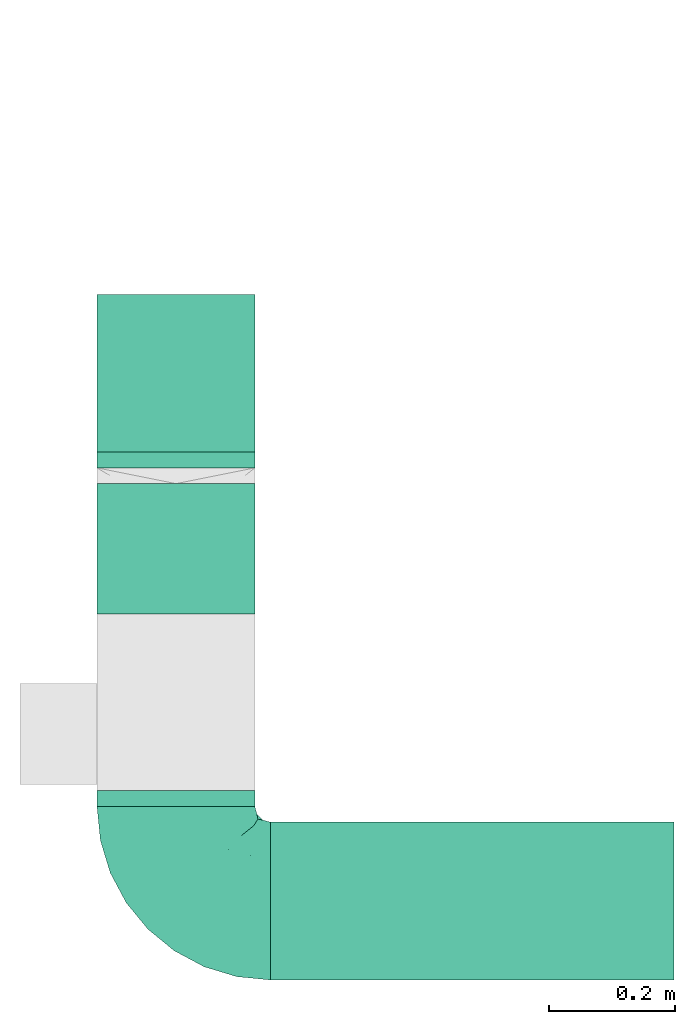
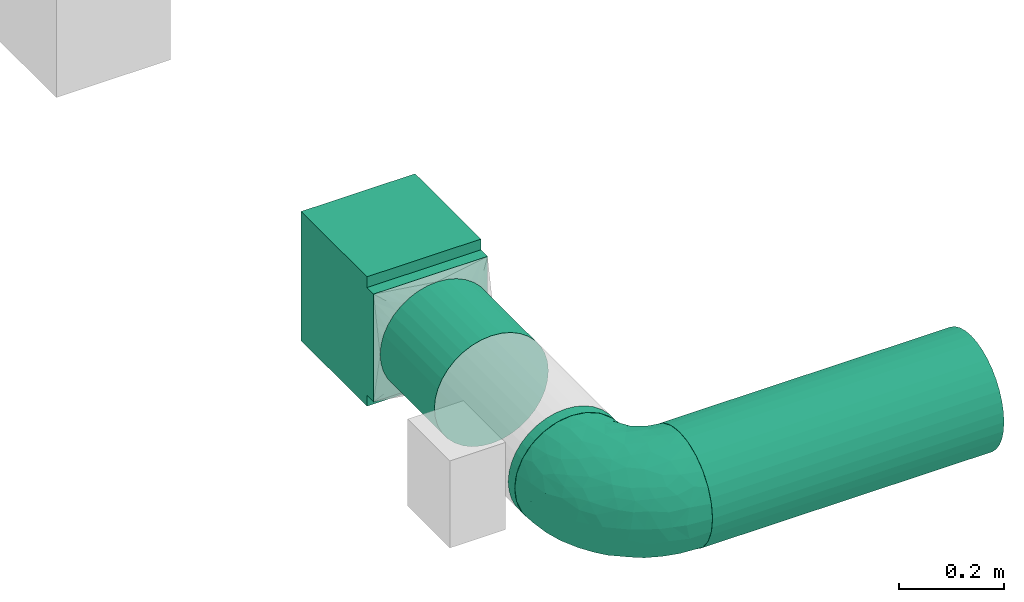
# One storey, part 1 of 4: 3 flow segments, 2 flow fittings.
"""IFC2X3 building model written with IfcOpenShell, lengths in millimetres."""

from ifc_helpers import new_model, entity, si_unit, converted_unit, derived_unit, direction, frame, origin, origin_2d_with_axis, place, context, subcontext, project, spatial, polyline, circle, outline, extrude, faceted_brep, source, transform, mapped, type_object, type_shapes, element, save


model = new_model("IFC2X3")

# Units and contexts
model_context = context("Model", 3, precision=0.01, world=origin(), true_north=direction((6.12303176911189e-17, 1.0)))
body_context = subcontext(model_context, "Body", "Model", "MODEL_VIEW")
ifc_project = project(units=[si_unit("LENGTHUNIT", "METRE", prefix="MILLI"), si_unit("AREAUNIT", "SQUARE_METRE"), si_unit("VOLUMEUNIT", "CUBIC_METRE"), converted_unit("PLANEANGLEUNIT", "DEGREE", entity("IfcRatioMeasure", 0.0174532925199433), si_unit("PLANEANGLEUNIT", "RADIAN"), dimensions=[0, 0, 0, 0, 0, 0, 0]), si_unit("MASSUNIT", "GRAM", prefix="KILO"), derived_unit("MASSDENSITYUNIT", [(si_unit("MASSUNIT", "GRAM", prefix="KILO"), 1), (si_unit("LENGTHUNIT", "METRE"), -3)]), si_unit("TIMEUNIT", "SECOND"), si_unit("FREQUENCYUNIT", "HERTZ"), si_unit("THERMODYNAMICTEMPERATUREUNIT", "DEGREE_CELSIUS"), derived_unit("THERMALTRANSMITTANCEUNIT", [(si_unit("MASSUNIT", "GRAM", prefix="KILO"), 1), (si_unit("THERMODYNAMICTEMPERATUREUNIT", "KELVIN"), -1), (si_unit("TIMEUNIT", "SECOND"), -3)]), derived_unit("VOLUMETRICFLOWRATEUNIT", [(si_unit("LENGTHUNIT", "METRE"), 3), (si_unit("TIMEUNIT", "SECOND"), -1)]), si_unit("ELECTRICCURRENTUNIT", "AMPERE"), si_unit("ELECTRICVOLTAGEUNIT", "VOLT"), si_unit("POWERUNIT", "WATT"), si_unit("FORCEUNIT", "NEWTON", prefix="KILO"), si_unit("ILLUMINANCEUNIT", "LUX"), si_unit("LUMINOUSFLUXUNIT", "LUMEN"), si_unit("LUMINOUSINTENSITYUNIT", "CANDELA"), derived_unit("USERDEFINED", [(si_unit("MASSUNIT", "GRAM", prefix="KILO"), -1), (si_unit("LENGTHUNIT", "METRE"), -2), (si_unit("TIMEUNIT", "SECOND"), 3), (si_unit("LUMINOUSFLUXUNIT", "LUMEN"), 1)]), derived_unit("LINEARVELOCITYUNIT", [(si_unit("LENGTHUNIT", "METRE"), 1), (si_unit("TIMEUNIT", "SECOND"), -1)]), si_unit("PRESSUREUNIT", "PASCAL"), derived_unit("USERDEFINED", [(si_unit("LENGTHUNIT", "METRE"), -2), (si_unit("MASSUNIT", "GRAM", prefix="KILO"), 1), (si_unit("TIMEUNIT", "SECOND"), -2)])], contexts=[model_context])

# Site, building, storey
site_placement = place(None, origin())
site = spatial("IfcSite", under=ifc_project, at=site_placement, CompositionType="ELEMENT")
building_placement = place(site_placement, origin())
building = spatial("IfcBuilding", under=site, at=building_placement, CompositionType="ELEMENT")
storey_placement = place(building_placement, frame((0.0, 0.0, 8000.0)))
storey = spatial("IfcBuildingStorey", under=building, at=storey_placement, Name="02 Level", CompositionType="ELEMENT", Elevation=8000.0)

# Flow segments
duct_segment_type = type_object("IfcDuctSegmentType", Name="Round Duct:Air", PredefinedType="NOTDEFINED")
flow_segment_1_placement = place(storey_placement, frame((25345.9632723171, -70384.05691443, 3383.40472776408)))
element("IfcFlowSegment", 1, at=flow_segment_1_placement, inside=storey, type_object=duct_segment_type, Name="Round Duct:Air", ObjectType="Round Duct:Air", context=body_context, shape_type="SweptSolid", body=[
    extrude(circle(Radius=125.0, at=origin_2d_with_axis()), frame((0.0, 126.595272235913, 126.595272235916), z_axis=(1.0, 0.0, 0.0), x_axis=(0.0, 1.0, 0.0)), (0.0, 0.0, 1.0), 639.200332511935),
])
flow_segment_2_placement = place(storey_placement, frame((25069.3680000811, -70107.4616421941, 3383.40472776408)))
element("IfcFlowSegment", 2, at=flow_segment_2_placement, inside=storey, type_object=duct_segment_type, Name="Round Duct:Air", ObjectType="Round Duct:Air", context=body_context, shape_type="SweptSolid", body=[
    extrude(circle(Radius=125.0, at=origin_2d_with_axis()), frame((126.595272235918, 0.0, 126.595272235916), z_axis=(0.0, 1.0, 0.0), x_axis=(1.0, 0.0, 0.0)), (0.0, 0.0, 1.0), 25.0000000001243),
])
flow_segment_3_placement = place(storey_placement, frame((25069.3680000811, -69802.4616421939, 3383.40472776408)))
element("IfcFlowSegment", 3, at=flow_segment_3_placement, inside=storey, type_object=duct_segment_type, Name="Round Duct:Air", ObjectType="Round Duct:Air", context=body_context, shape_type="SweptSolid", body=[
    extrude(circle(Radius=125.0, at=origin_2d_with_axis()), frame((126.595272235918, 0.0, 126.595272235916), z_axis=(0.0, 1.0, 0.0), x_axis=(1.0, 0.0, 0.0)), (0.0, 0.0, 1.0), 206.222057054006),
])

# Flow fittings
duct_fitting_type_1 = type_object("IfcDuctFittingType", Name="Air_Elbow short_Circ", PredefinedType="NOTDEFINED")
shared_shape_1 = source(origin(), body_context, "Body", "Brep", [
    faceted_brep([(-150.0, 0.0, -125.0), (-150.0, -32.3523806378149, -120.740728286134), (-150.0, -62.4999999999998, -108.253175473055), (-150.0, -88.3883476483182, -88.3883476483186), (-150.0, -108.253175473055, -62.5000000000003), (-150.0, -120.740728286133, -32.3523806378155), (-150.0, -123.435651957388, -11.8824030784058), (-150.0, -125.0, 0.0), (-150.0, -123.435651932551, 11.8824032670586), (-150.0, -120.740728286134, 32.3523806378147), (-150.0, -108.253175473055, 62.4999999999996), (-150.0, -88.3883476483188, 88.3883476483181), (-150.0, -62.5000000000004, 108.253175473055), (-150.0, -32.3523806378156, 120.740728286133), (-150.0, 0.0, 125.0), (-150.0, 32.3523806378145, 120.740728286134), (-150.0, 47.426190318907, 114.496951879594), (-150.0, 62.4999999999994, 108.253175473055), (-150.0, 88.3883476483179, 88.3883476483189), (-150.0, 108.253175473054, 62.5000000000006), (-150.0, 120.740728286133, 32.3523806378158), (-150.0, 125.0, 0.0), (-150.0, 120.740728286134, -32.3523806378151), (-150.0, 108.253175473055, -62.4999999999999), (-150.0, 88.3883476483185, -88.3883476483184), (-150.0, 62.5000000000001, -108.253175473055), (-150.0, 32.3523806378152, -120.740728286134), (-32.3523806378144, 150.0, -120.740728286134), (-47.4261903189069, 150.0, -114.496951879594), (-62.4999999999993, 150.0, -108.253175473055), (-88.3883476483177, 150.0, -88.3883476483184), (-108.253175473054, 150.0, -62.4999999999999), (-120.740728286133, 150.0, -32.3523806378151), (-125.0, 150.0, 0.0), (-120.740728286133, 150.0, 32.3523806378158), (-108.253175473054, 150.0, 62.5000000000006), (-88.3883476483171, 150.0, 88.3883476483189), (-62.4999999999986, 150.0, 108.253175473055), (-32.3523806378137, 150.0, 120.740728286134), (0.0, 150.0, 125.0), (32.3523806378164, 150.0, 120.740728286133), (62.5000000000013, 150.0, 108.253175473055), (88.3883476483196, 150.0, 88.3883476483181), (108.253175473056, 150.0, 62.4999999999996), (120.740728286134, 150.0, 32.3523806378147), (123.435651942407, 150.0, 11.8824031922038), (125.0, 150.0, 0.0), (123.435651967915, 150.0, -11.8824029984461), (120.740728286134, 150.0, -32.3523806378155), (108.253175473056, 150.0, -62.5000000000003), (88.3883476483191, 150.0, -88.3883476483186), (62.5000000000006, 150.0, -108.253175473055), (32.3523806378157, 150.0, -120.740728286134), (0.0, 150.0, -125.0), (78.654143383201, -2.78181408039032, 0.0), (76.8166118284912, 4.34215934351885, 36.4784551593461), (61.5542541047513, -23.6180894533453, 0.0), (-134.47520521655, -123.470941174946, 0.0), (-118.950410719399, -121.94188237809, 0.0), (-107.650286082481, -120.828917244489, 0.0), (-104.978291071801, -115.896211779269, 36.0762953828009), (-104.893239881748, -80.8641300661028, 91.4382355521353), (-72.3157335278814, -68.3433914970576, 94.5606631552989), (-98.4001040789566, -53.9628430343128, 109.445004780609), (-96.3501614455635, -119.715952110888, 0.0), (-42.4833938815038, 107.782088248638, 120.147094064889), (-9.85362544116063, 110.378344389653, 124.923923156167), (-65.0280946569744, -106.747383493999, 33.443557785531), (-86.153263795542, -100.695403874887, 61.7233478403087), (-46.6576932994355, -45.2628664218306, 102.931281147801), (-74.6225764033372, -21.2831891292868, 119.356425571857), (-72.3472176796021, 118.598046915095, 106.00707228478), (-30.181321363474, -90.8187429032163, 38.3247326160971), (-70.5561087725814, -111.891411775746, 0.0), (-122.641019976636, -101.950353756475, 70.1921456806148), (-116.029933078324, -22.4446697961388, 122.317161759311), (31.0815829535711, -16.1832151821723, 80.3202993154639), (-6.5545406401204, -44.0646866272317, 85.350831949551), (-3.87227453406602, -60.0293001979925, 66.4690229889152), (-124.863076426312, 35.02364091556, 120.752635411014), (-108.839291442555, 9.81519021738238, 124.939227930759), (-65.2460766604593, 23.6299006304857, 124.981338254694), (-100.878102436648, 43.0002899009219, 120.764526140437), (-19.3649461243935, 39.6901954019144, 123.22697540265), (-40.0496486471489, 1.9751024241996, 120.175633139922), (115.896212240375, 104.978289788922, 36.076293164084), (106.747383973922, 65.0280912143933, 33.4435522492635), (111.891411775747, 70.5561087725829, 0.0), (-128.779008055589, 97.2792215313154, 83.3343675755997), (-129.846276411156, 129.84627642804, 29.3795101662085), (-137.499999999999, 128.349364905389, 0.0), (-119.508978979081, 123.341462022577, 60.2918029167743), (-117.382833556128, 72.4228430829308, 106.251870907854), (-25.6262961621547, 80.1753214783878, 124.782747564482), (-131.548236956176, 110.790620858511, 65.1719471748524), (-8.79719392560859, -75.269004466267, 46.9066376982592), (-35.2869113408269, -83.3156317546561, 59.3885364241187), (80.8641305584726, 104.893240937849, 91.4382352904789), (22.4446672811422, 116.029929681511, 122.317162140699), (53.9628368321699, 98.4001001508859, 109.445007566679), (101.950355286479, 122.641017340516, 70.1921430199164), (-81.9960770469301, 82.9111806812523, 112.506499839482), (121.941882232658, 118.950409242795, 0.0), (71.251669566406, 11.4744102833441, 57.4040159418747), (72.0838963385765, 41.0064832243528, 78.3617835611187), (54.4859475333804, 9.97269301512521, 77.8031341973232), (23.6180894533467, -61.55425410475, 0.0), (32.5558794954592, -52.5906940820025, 23.8275763366719), (5.67366256371018, -73.4168733312184, 25.8218410570659), (-104.061743134415, 104.061741649423, 91.6204401768965), (100.695405783636, 86.1532561367086, 61.7233412541476), (85.8987630246562, 72.298942037013, 77.1305759551526), (45.2628557573736, 46.657677121917, 102.931282428265), (21.2831826839793, 74.6225676704571, 119.356426312895), (-128.349364905388, 137.5, 0.0), (-97.2792212827368, 128.779007172919, 83.3343682018964), (44.4543648263017, -44.4543648263003, 0.0), (-52.705139116163, 62.5335134626551, 123.521409265362), (-44.7620560995991, -104.066871440604, 0.0), (68.3433809087284, 72.3157185192085, 94.5606674302311), (39.0643086961098, -39.0643160658399, 42.9833221935425), (16.162962522349, -57.6081885852494, 46.7813378836038), (87.2978457655956, 45.1469719017519, 60.4141052051649), (-73.6770751262291, 45.4290804428845, 123.301126563982), (91.3605074119029, 20.9901210096052, 0.0), (104.066871440605, 44.7620560996006, 0.0), (90.8187420929716, 30.1813146205812, 38.3247255432369), (24.8419677176115, 18.7098050381526, 104.4628615233), (46.9444181295578, -18.5239913801244, 60.8208891980822), (13.0080717069866, -10.2820614252128, 97.1887902869043), (-29.5778446799892, -20.3201363536925, 110.417514778129), (-1.53394209146154, 80.1817000123714, 124.206375369784), (-65.4894356396677, -87.5368940232825, 72.0830916827234), (-3.04954297208558, 3.04952905280945, 110.823842282024), (9.92439824324807, 37.6446897703782, 116.445568419899), (2.7818140803917, -78.6541433831998, 0.0), (59.4075113977493, -18.3919768641063, 39.1397493302004), (-41.0065082221364, -72.0839038715865, 78.3617888442077), (-20.9901210096037, -91.3605074119017, 0.0), (119.715952110889, 96.3501614455651, 0.0), (-39.6901857853554, 19.3649451890522, -123.226974224734), (-62.5335140350356, 52.7051321522757, -123.521410009679), (-23.6299179988057, 65.2460778291534, -124.981338515222), (52.5906917601974, -32.5558816629036, -23.8275777472421), (73.4168733742841, -5.67366166885961, -25.8218433127719), (-110.378347073661, 9.85362190254904, -124.923923249535), (-35.0236472156293, 124.863059021426, -120.752634758897), (-107.782088925523, 42.4833910778036, -120.147094743061), (-104.978289397083, -115.896211531471, -36.0762952658108), (-86.1532622275364, -100.695403598284, -61.7233476308542), (-65.0280943433708, -106.747382926782, -33.4435593699909), (-129.846276430226, 129.846276387071, -29.3795102302433), (-110.790620399346, 131.548235360156, -65.1719489671012), (-123.341462756194, 119.508979301124, -60.291801599493), (-104.061744765902, 104.061740157582, -91.6204400852508), (-128.779008894392, 97.2792211868359, -83.3343675827014), (53.9628420250463, 98.4000971565888, -109.445004383699), (-118.598049105409, 72.3472165670435, -106.007072416171), (-82.9111719502085, 81.9960693312282, -112.50650546776), (-122.641019448242, -101.950353750649, -70.1921456050946), (-104.893238223024, -80.8641303146933, -91.4382350282511), (-98.4001019855057, -53.9628440035923, -109.445003978822), (80.8641292666627, 104.893234920637, -91.4382353967358), (-11.4744255033641, -71.2516789045734, -57.4040162551542), (-41.0065049684125, -72.0839032542554, -78.3617877513776), (-9.97270838371827, -54.485960500352, -77.8031316627462), (-4.34216444876671, -76.8166149897799, -36.4784554826068), (-80.1753222808587, 25.6262887954871, -124.782747920507), (-116.029931420384, -22.4446712385047, -122.317161393809), (68.3433887340013, 72.3157292909759, -94.5606641780198), (45.2628607882706, 46.6576825738772, -102.931281121668), (22.4446699556419, 116.029925989706, -122.317161437833), (-9.8151830458522, 108.839262459516, -124.939228400111), (-72.298953284581, -85.8987604849819, -77.1305835190378), (-97.2792209116865, 128.779005996318, -83.3343690779209), (-46.6576894105135, -45.2628676819038, -102.931279126956), (-72.3157308447408, -68.3433918222031, -94.5606621128927), (-72.422840670004, 117.382841409987, -106.251870399877), (21.2831853090833, 74.6225640045938, -119.356425105916), (101.950353353368, 122.641019823701, -70.1921462468134), (-43.0003002529277, 100.878091329174, -120.764524865091), (16.1832033989244, -31.0815970254922, -80.3202964529749), (44.0646797153192, 6.55452919959333, -85.3508306205825), (60.0292953493994, 3.87226817055985, -66.4690235395615), (115.896211010696, 104.978286786289, -36.0762955232767), (106.747381524869, 65.0280939101863, -33.4435636729749), (100.695402688448, 86.1532621979624, -61.7233491707037), (-1.97512261791953, 40.0496336831204, -120.175635225652), (83.315631357607, 35.2869127496766, -59.388538235289), (90.8187416032175, 30.181318578684, -38.3247323782698), (75.2690016288807, 8.79719117487841, -46.9066400280846), (18.5239820708271, -46.9444270147629, -60.8208879439308), (57.6081840561054, -16.162966744892, -46.7813401074288), (39.0643108807276, -39.0643133486842, -42.9833232218422), (-74.6225723501512, -21.2831916140966, -119.356424356291), (-45.1469861494655, -87.2978481709874, -60.4141116504016), (-45.4290965712264, 73.6770713110896, -123.301124768617), (-30.1813201883898, -90.818742779246, -38.3247313356157), (-18.7098212867178, -24.8419796072181, -104.462861687025), (10.2820459472016, -13.0080933749158, -97.1887865677227), (20.3201251027192, 29.5778424846975, -110.417518980415), (-80.1817048843535, 1.5339337664806, -124.206374751548), (87.5368918123803, 65.4894359750046, -72.0830947930252), (-3.04953343548765, 3.04952712079592, -110.823838051094), (-37.6446965781717, -9.92440491577136, -116.445567816425), (18.3919716152399, -59.4075155656008, -39.1397494553499), (72.083900742128, 41.0065066004899, -78.361791447751)], [[[0, 1, 2, 3, 4, 5, 6, 7, 8, 9, 10, 11, 12, 13, 14, 15, 16, 17, 18, 19, 20, 21, 22, 23, 24, 25, 26]], [[27, 28, 29, 30, 31, 32, 33, 34, 35, 36, 37, 38, 39, 40, 41, 42, 43, 44, 45, 46, 47, 48, 49, 50, 51, 52, 53]], [[54, 55, 56]], [[9, 8, 7, 57, 58, 59]], [[60, 10, 9]], [[61, 62, 63]], [[60, 59, 64]], [[38, 65, 66]], [[60, 67, 68]], [[12, 11, 61]], [[63, 12, 61]], [[63, 69, 70]], [[37, 36, 71]], [[72, 68, 67]], [[60, 73, 67]], [[11, 10, 74]], [[37, 71, 65]], [[13, 75, 14]], [[76, 77, 78]], [[17, 16, 15, 79]], [[80, 81, 82]], [[83, 81, 84]], [[85, 86, 87]], [[18, 88, 19]], [[89, 21, 20]], [[21, 89, 90]], [[89, 91, 34]], [[63, 62, 69]], [[17, 92, 18]], [[93, 66, 65]], [[19, 88, 94]], [[63, 70, 75]], [[95, 96, 72]], [[74, 60, 68]], [[41, 97, 42]], [[13, 12, 63]], [[40, 98, 99]], [[43, 42, 100]], [[65, 71, 101]], [[41, 40, 99]], [[85, 102, 44]], [[103, 104, 105]], [[41, 99, 97]], [[85, 44, 43]], [[106, 107, 108]], [[79, 92, 17]], [[102, 46, 45, 44]], [[71, 109, 101]], [[85, 110, 86]], [[97, 111, 110]], [[33, 89, 34]], [[112, 99, 113]], [[114, 89, 33]], [[94, 20, 19]], [[115, 91, 109]], [[116, 107, 106]], [[117, 81, 83]], [[91, 35, 34]], [[36, 35, 115]], [[118, 72, 67]], [[15, 14, 80]], [[112, 104, 119]], [[65, 38, 37]], [[66, 39, 38]], [[107, 120, 121]], [[122, 86, 110]], [[39, 98, 40]], [[75, 80, 14]], [[100, 85, 43]], [[123, 81, 117]], [[82, 123, 101]], [[88, 92, 109]], [[124, 125, 126]], [[127, 105, 112]], [[121, 128, 76]], [[77, 129, 130]], [[115, 71, 36]], [[109, 92, 101]], [[93, 65, 117]], [[66, 131, 98]], [[119, 97, 99]], [[100, 97, 110]], [[74, 61, 11]], [[132, 68, 96]], [[80, 70, 81]], [[84, 81, 70]], [[133, 134, 83]], [[93, 131, 66]], [[135, 106, 108]], [[72, 108, 95]], [[110, 111, 122]], [[136, 116, 56]], [[134, 112, 113]], [[112, 134, 127]], [[77, 69, 137]], [[84, 130, 133]], [[96, 78, 137]], [[129, 76, 127]], [[82, 101, 92]], [[65, 101, 117]], [[66, 98, 39]], [[99, 98, 113]], [[63, 75, 13]], [[80, 75, 70]], [[91, 115, 35]], [[71, 115, 109]], [[92, 88, 18]], [[94, 109, 91]], [[86, 125, 87]], [[135, 108, 138]], [[125, 86, 126]], [[87, 139, 85]], [[117, 83, 93]], [[83, 134, 131]], [[83, 131, 93]], [[98, 131, 113]], [[109, 94, 88]], [[94, 91, 89]], [[9, 59, 60]], [[102, 85, 139]], [[90, 89, 114]], [[89, 20, 94]], [[60, 74, 10]], [[61, 74, 68]], [[97, 100, 42]], [[85, 100, 110]], [[82, 92, 79]], [[15, 80, 79]], [[80, 82, 79]], [[121, 108, 107]], [[136, 107, 116]], [[112, 119, 99]], [[95, 108, 121]], [[108, 72, 138]], [[78, 95, 121]], [[95, 78, 96]], [[76, 78, 121]], [[137, 78, 77]], [[132, 96, 137]], [[68, 72, 96]], [[62, 132, 137]], [[61, 68, 132]], [[128, 120, 136]], [[121, 120, 128]], [[103, 128, 136]], [[128, 103, 105]], [[55, 103, 136]], [[122, 103, 126]], [[112, 105, 104]], [[128, 105, 76]], [[55, 126, 103]], [[136, 120, 107]], [[111, 119, 104]], [[119, 111, 97]], [[122, 111, 104]], [[103, 122, 104]], [[122, 126, 86]], [[132, 62, 61]], [[69, 62, 137]], [[101, 123, 117]], [[82, 81, 123]], [[130, 70, 69]], [[83, 84, 133]], [[70, 130, 84]], [[77, 130, 69]], [[134, 133, 127]], [[131, 134, 113]], [[129, 127, 133]], [[105, 127, 76]], [[130, 129, 133]], [[77, 76, 129]], [[72, 118, 138]], [[55, 124, 126]], [[73, 60, 64]], [[73, 118, 67]], [[56, 55, 136]], [[124, 55, 54]], [[140, 141, 142]], [[56, 143, 144]], [[145, 0, 26]], [[28, 27, 146, 29]], [[25, 147, 26]], [[148, 149, 150]], [[90, 151, 21]], [[152, 32, 31]], [[153, 154, 155]], [[56, 116, 143]], [[155, 24, 23]], [[52, 51, 156]], [[147, 157, 158]], [[22, 153, 23]], [[4, 148, 5]], [[25, 24, 157]], [[57, 7, 6, 5, 58]], [[159, 148, 4]], [[160, 2, 161]], [[51, 50, 162]], [[160, 3, 2]], [[163, 164, 165]], [[4, 3, 159]], [[135, 166, 106]], [[167, 145, 147]], [[2, 1, 161]], [[168, 161, 1]], [[157, 154, 158]], [[156, 169, 170]], [[151, 90, 114]], [[171, 172, 53]], [[33, 32, 151]], [[160, 173, 149]], [[31, 174, 152]], [[175, 164, 176]], [[146, 177, 29]], [[30, 174, 31]], [[157, 147, 25]], [[52, 171, 53]], [[156, 178, 171]], [[50, 49, 179]], [[172, 142, 180]], [[181, 182, 183]], [[177, 30, 29]], [[27, 53, 172]], [[0, 168, 1]], [[170, 178, 156]], [[184, 185, 186]], [[140, 142, 187]], [[188, 189, 190]], [[26, 147, 145]], [[51, 162, 156]], [[186, 185, 189]], [[191, 192, 193]], [[102, 139, 184]], [[48, 102, 184]], [[151, 153, 22]], [[184, 49, 48]], [[175, 161, 194]], [[169, 156, 162]], [[144, 189, 124]], [[148, 150, 73]], [[184, 87, 185]], [[114, 33, 151]], [[179, 184, 186]], [[195, 150, 149]], [[180, 142, 196]], [[180, 196, 158]], [[174, 177, 154]], [[118, 150, 197]], [[198, 165, 175]], [[163, 165, 191]], [[182, 199, 200]], [[155, 157, 24]], [[154, 177, 158]], [[167, 147, 141]], [[145, 201, 168]], [[176, 160, 161]], [[159, 160, 149]], [[179, 162, 50]], [[202, 186, 188]], [[172, 178, 142]], [[187, 142, 178]], [[203, 204, 140]], [[167, 201, 145]], [[54, 56, 144]], [[189, 144, 190]], [[149, 173, 195]], [[205, 116, 106]], [[204, 175, 194]], [[175, 204, 198]], [[182, 170, 206]], [[187, 200, 203]], [[188, 183, 206]], [[199, 181, 198]], [[180, 158, 177]], [[147, 158, 141]], [[145, 168, 0]], [[161, 168, 194]], [[156, 171, 52]], [[172, 171, 178]], [[153, 155, 23]], [[157, 155, 154]], [[177, 174, 30]], [[152, 154, 153]], [[150, 118, 73]], [[87, 184, 139]], [[166, 138, 197]], [[73, 64, 148]], [[141, 140, 167]], [[140, 204, 201]], [[140, 201, 167]], [[168, 201, 194]], [[154, 152, 174]], [[152, 153, 151]], [[148, 64, 59, 58]], [[5, 148, 58]], [[47, 46, 102, 48]], [[151, 32, 152]], [[151, 22, 21]], [[184, 179, 49]], [[162, 179, 186]], [[160, 159, 3]], [[148, 159, 149]], [[180, 177, 146]], [[27, 172, 146]], [[172, 180, 146]], [[143, 193, 192]], [[143, 116, 205]], [[143, 192, 144]], [[190, 144, 192]], [[189, 125, 124]], [[183, 190, 192]], [[190, 183, 188]], [[181, 183, 192]], [[206, 183, 182]], [[202, 188, 206]], [[186, 189, 188]], [[169, 202, 206]], [[162, 186, 202]], [[175, 176, 161]], [[191, 193, 205]], [[191, 205, 163]], [[192, 191, 181]], [[166, 163, 205]], [[195, 163, 197]], [[175, 165, 164]], [[191, 165, 181]], [[166, 197, 163]], [[205, 193, 143]], [[173, 176, 164]], [[176, 173, 160]], [[195, 173, 164]], [[163, 195, 164]], [[195, 197, 150]], [[202, 169, 162]], [[170, 169, 206]], [[142, 141, 196]], [[158, 196, 141]], [[200, 178, 170]], [[140, 187, 203]], [[178, 200, 187]], [[182, 200, 170]], [[204, 203, 198]], [[201, 204, 194]], [[199, 198, 203]], [[165, 198, 181]], [[200, 199, 203]], [[182, 181, 199]], [[125, 189, 185]], [[54, 144, 124]], [[138, 118, 197]], [[87, 125, 185]], [[106, 166, 205]], [[138, 166, 135]]]),
])
type_shapes(duct_fitting_type_1, [shared_shape_1])
flow_fitting_1_placement = place(storey_placement, frame((25195.9632723171, -70257.4616421941, 3510.0), z_axis=(0.0, 0.0, 1.0), x_axis=(0.0, -1.0, 0.0)))
element("IfcFlowFitting", 4, at=flow_fitting_1_placement, inside=storey, type_object=duct_fitting_type_1, Name="elbow_short_001:Air_Elbow short_Circ", ObjectType="elbow_short_001:Air_Elbow short_Circ", context=body_context, shape_type="MappedRepresentation", body=[
    mapped(shared_shape_1, transform((0.0, 0.0, 0.0), scale=1.0)),
])
duct_fitting_type_2 = type_object("IfcDuctFittingType", Name="Air_Rect", PredefinedType="NOTDEFINED")
shared_shape_2 = source(origin(), body_context, "Body", "SweptSolid", [
    extrude(outline(polyline([(-150.0, 56.2500000000001), (-150.0, -193.75), (150.0, -193.75), (150.0, 56.25), (125.0, 56.25), (125.0, 81.2499999999995), (-125.0, 81.2500000000003), (-125.0, 56.2500000000001), (-150.0, 56.2500000000001)])), frame((0.0, -68.75, -125.0), z_axis=(0.0, 0.0, -1.0), x_axis=(1.0, 0.0, 0.0)), (0.0, 0.0, -1.0), 250.0),
])
type_shapes(duct_fitting_type_2, [shared_shape_2])
flow_fitting_2_placement = place(storey_placement, frame((25195.9632723171, -69421.2395851399, 3510.0), z_axis=(1.0, 0.0, 0.0), x_axis=(0.0, 0.0, -1.0)))
element("IfcFlowFitting", 5, at=flow_fitting_2_placement, inside=storey, type_object=duct_fitting_type_2, Name="1_001:Air_Rect", ObjectType="1_001:Air_Rect", context=body_context, shape_type="MappedRepresentation", body=[
    mapped(shared_shape_2, transform((0.0, 0.0, 0.0), scale=1.0)),
])

save(model, "model.ifc")
